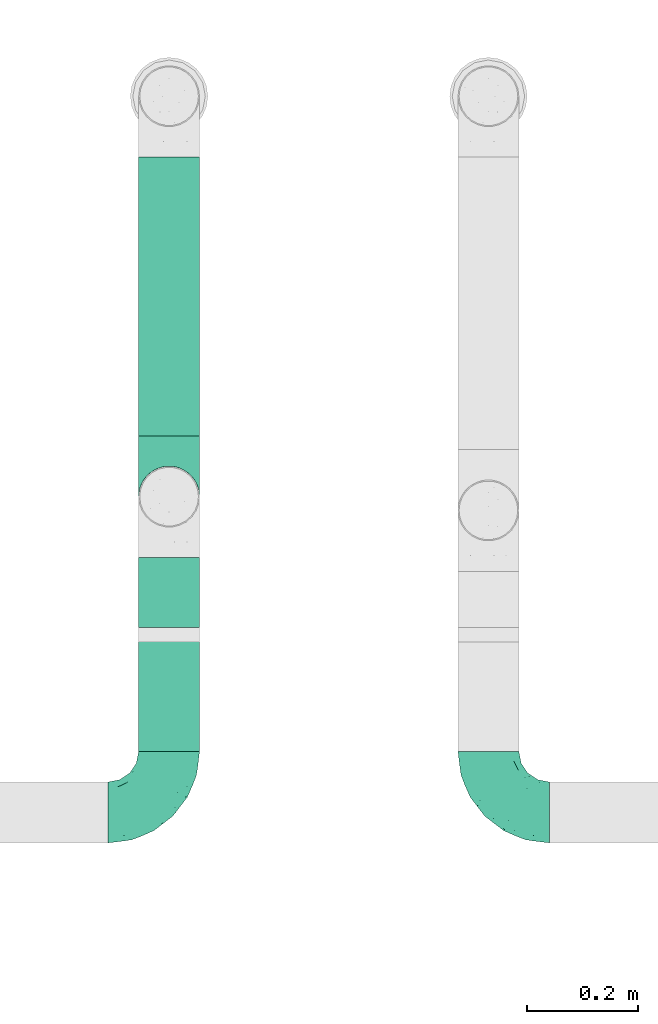
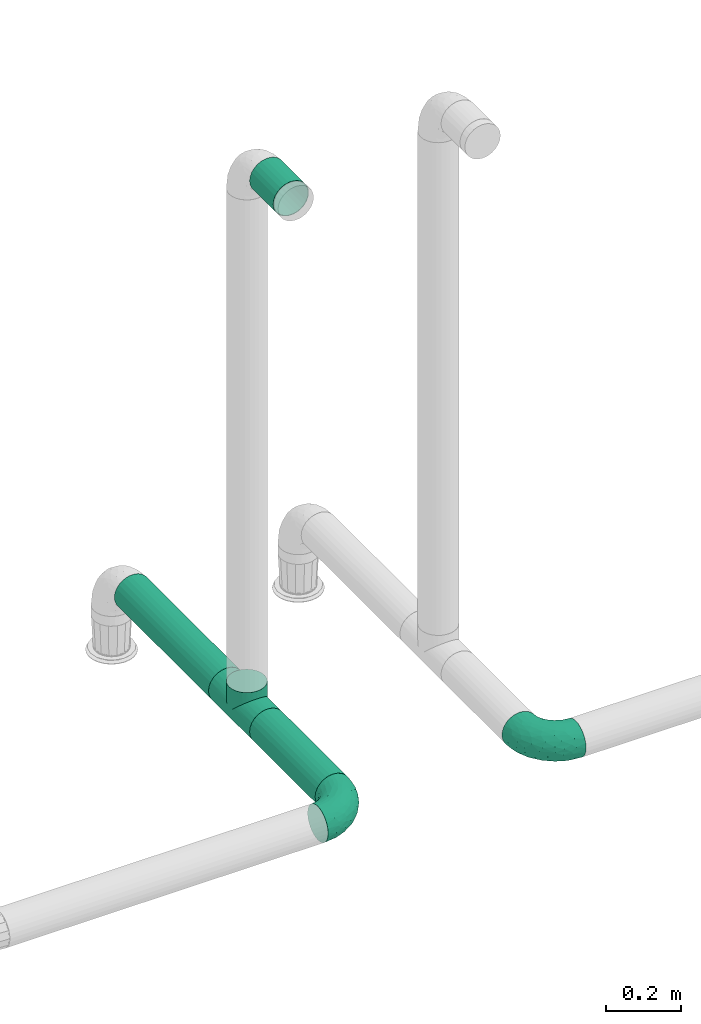
# One storey, part 58 of 103: 3 flow fittings, 3 flow segments.
"""IFC2X3 building model written with IfcOpenShell, lengths in millimetres."""

from ifc_helpers import new_model, entity, si_unit, converted_unit, derived_unit, direction, frame, origin_with_axes, origin_2d_with_axis, place, context, subcontext, project, spatial, hollow_circle, extrude, open_shell, surface_model, source, transform, mapped, material, layer, layer_set, layer_usage, type_object, element, save


model = new_model("IFC2X3")

# Units and contexts
model_context = context("Model", 3, precision=1e-05, world=origin_with_axes(), true_north=direction((0.0, 1.0)))
body_context = subcontext(model_context, "Body", "Model", "MODEL_VIEW")
ifc_project = project(units=[si_unit("AREAUNIT", "SQUARE_METRE"), si_unit("VOLUMEUNIT", "CUBIC_METRE", prefix="DECI"), si_unit("TIMEUNIT", "SECOND"), si_unit("THERMODYNAMICTEMPERATUREUNIT", "DEGREE_CELSIUS"), si_unit("PRESSUREUNIT", "PASCAL"), si_unit("MASSUNIT", "GRAM", prefix="KILO"), si_unit("LENGTHUNIT", "METRE", prefix="MILLI"), si_unit("POWERUNIT", "WATT"), si_unit("ELECTRICCURRENTUNIT", "AMPERE"), si_unit("ELECTRICVOLTAGEUNIT", "VOLT"), derived_unit("VOLUMETRICFLOWRATEUNIT", [(si_unit("VOLUMEUNIT", "CUBIC_METRE", prefix="DECI"), 1), (si_unit("TIMEUNIT", "SECOND"), -1)]), derived_unit("LINEARVELOCITYUNIT", [(si_unit("LENGTHUNIT", "METRE"), 1), (si_unit("TIMEUNIT", "SECOND"), -1)]), derived_unit("MASSDENSITYUNIT", [(si_unit("MASSUNIT", "GRAM", prefix="KILO"), 1), (si_unit("VOLUMEUNIT", "CUBIC_METRE"), -1)]), converted_unit("PLANEANGLEUNIT", "DEGREE", entity("IfcRatioMeasure", 0.01745), si_unit("PLANEANGLEUNIT", "RADIAN"), dimensions=[0, 0, 0, 0, 0, 0, 0])], contexts=[model_context])

# Site, building, storey
site_placement = place(None, origin_with_axes())
site = spatial("IfcSite", under=ifc_project, at=site_placement, CompositionType="ELEMENT")
building_placement = place(site_placement, origin_with_axes())
building = spatial("IfcBuilding", under=site, at=building_placement, Name="mc-building", CompositionType="ELEMENT")
storey_placement = place(building_placement, frame((0.0, 0.0, 5900.0), z_axis=(0.0, 0.0, 1.0), x_axis=(1.0, 0.0, 0.0)))
storey = spatial("IfcBuildingStorey", under=building, at=storey_placement, Name="3. Korrus", CompositionType="ELEMENT", Elevation=5900.0)

# Flow fittings
duct_fitting_type_1 = type_object("IfcDuctFittingType", PredefinedType="JUNCTION")
shared_shape_1 = source(origin_with_axes(), body_context, "Body", "SurfaceModel", [
    surface_model("IfcShellBasedSurfaceModel", [(0.0, -80.0, -55.0), (14.23505, -80.0, -53.12592), (-14.23505, -80.0, -53.12592), (-53.12592, -80.0, 14.23505), (-27.5, -80.0, -47.63139), (-47.63139, -80.0, -27.5), (-38.89087, -80.0, -38.89087), (55.0, -80.0, 0.0), (53.12592, -80.0, 14.23505), (38.89087, -80.0, -38.89087), (27.5, -80.0, -47.63139), (53.12592, -80.0, -14.23505), (47.63139, -80.0, -27.5), (-53.12592, -80.0, -14.23505), (-47.63139, -80.0, 27.5), (-38.89087, -80.0, 38.89087), (14.23505, -80.0, 53.12592), (-27.5, -80.0, 47.63139), (-14.23505, -80.0, 53.12592), (47.63139, -80.0, 27.5), (38.89087, -80.0, 38.89087), (27.5, -80.0, 47.63139), (0.0, -80.0, 55.0), (-55.0, -80.0, 0.0), (0.0, 0.0, 55.0), (-7.4066, -7.4066, 54.49901), (-14.74521, -14.74521, 52.98659), (-21.93978, -21.93978, 50.43457), (-28.89905, -28.89905, 46.79578), (-35.50357, -35.50357, 42.00591), (-41.58668, -41.58668, 35.99373), (-46.92319, -46.92319, 28.69171), (-51.19777, -51.19777, 20.0945), (-50.37866, -80.0, 20.86752), (-54.01174, -54.01174, 10.37938), (-55.0, -55.0, 0.0), (-54.06296, -80.0, 7.11752), (-54.01174, -54.01174, -10.37938), (-51.19777, -51.19777, -20.0945), (-54.06296, -80.0, -7.11752), (-46.92319, -46.92319, -28.69171), (-41.58668, -41.58668, -35.99373), (-50.37866, -80.0, -20.86752), (-35.50357, -35.50357, -42.00591), (-21.93978, -21.93978, -50.43457), (-14.74521, -14.74521, -52.98659), (-7.4066, -7.4066, -54.49901), (0.0, 0.0, -55.0), (-28.89905, -28.89905, -46.79578), (7.4066, -7.4066, -54.49901), (14.74521, -14.74521, -52.98659), (21.93978, -21.93978, -50.43457), (28.89905, -28.89905, -46.79578), (35.50357, -35.50357, -42.00591), (41.58668, -41.58668, -35.99373), (46.92319, -46.92319, -28.69171), (51.19777, -51.19777, -20.0945), (50.37866, -80.0, -20.86752), (54.01174, -54.01174, -10.37938), (55.0, -55.0, 0.0), (54.06296, -80.0, -7.11752), (54.01174, -54.01174, 10.37938), (51.19777, -51.19777, 20.0945), (54.06296, -80.0, 7.11752), (46.92319, -46.92319, 28.69171), (41.58668, -41.58668, 35.99373), (50.37866, -80.0, 20.86752), (35.50357, -35.50357, 42.00591), (21.93978, -21.93978, 50.43457), (14.74521, -14.74521, 52.98659), (7.4066, -7.4066, 54.49901), (28.89905, -28.89905, 46.79578), (-110.0, 0.0, -55.0), (-110.0, -14.23505, -53.12592), (-110.0, 14.23505, -53.12592), (-110.0, 53.12592, 14.23505), (-110.0, 27.5, -47.63139), (-110.0, 47.63139, -27.5), (-110.0, 38.89087, -38.89087), (-110.0, -55.0, 0.0), (-110.0, -53.12592, 14.23505), (-110.0, -38.89087, -38.89087), (-110.0, -27.5, -47.63139), (-110.0, -53.12592, -14.23505), (-110.0, -47.63139, -27.5), (-110.0, 53.12592, -14.23505), (-110.0, 47.63139, 27.5), (-110.0, 38.89087, 38.89087), (-110.0, -14.23505, 53.12592), (-110.0, 27.5, 47.63139), (-110.0, 14.23505, 53.12592), (-110.0, -47.63139, 27.5), (-110.0, -38.89087, 38.89087), (-110.0, -27.5, 47.63139), (-110.0, 0.0, 55.0), (-110.0, 55.0, 0.0), (110.0, 55.0, 0.0), (110.0, 0.0, -55.0), (110.0, 14.23505, -53.12592), (110.0, 27.5, -47.63139), (110.0, 38.89087, -38.89087), (110.0, 47.63139, -27.5), (110.0, -38.89087, -38.89087), (110.0, -53.12592, 14.23505), (110.0, -27.5, -47.63139), (110.0, -14.23505, -53.12592), (110.0, -47.63139, -27.5), (110.0, -53.12592, -14.23505), (110.0, -55.0, 0.0), (110.0, 53.12592, -14.23505), (110.0, 53.12592, 14.23505), (110.0, 47.63139, 27.5), (110.0, 38.89087, 38.89087), (110.0, 0.0, 55.0), (110.0, 27.5, 47.63139), (110.0, 14.23505, 53.12592), (110.0, -47.63139, 27.5), (110.0, -38.89087, 38.89087), (110.0, -27.5, 47.63139), (110.0, -14.23505, 53.12592)], [open_shell([[[0, 1, 2]], [[2, 3, 4]], [[5, 6, 3]], [[6, 4, 3]], [[2, 7, 8]], [[9, 7, 10]], [[1, 10, 7]], [[11, 7, 12]], [[9, 12, 7]], [[7, 2, 1]], [[5, 3, 13]], [[2, 14, 3]], [[2, 15, 14]], [[2, 16, 17]], [[17, 15, 2]], [[16, 18, 17]], [[2, 8, 19]], [[2, 19, 20]], [[2, 20, 21]], [[16, 2, 21]], [[16, 22, 18]], [[23, 13, 3]], [[24, 25, 22]], [[26, 27, 18]], [[25, 26, 18]], [[22, 25, 18]], [[17, 28, 29]], [[17, 18, 27]], [[17, 29, 15]], [[28, 17, 27]], [[30, 31, 14]], [[32, 3, 33]], [[32, 34, 3]], [[35, 36, 34]], [[31, 32, 14]], [[15, 30, 14]], [[34, 36, 3]], [[33, 14, 32]], [[36, 35, 23]], [[30, 15, 29]], [[37, 38, 13]], [[37, 13, 39]], [[40, 41, 5]], [[38, 5, 42]], [[38, 40, 5]], [[37, 39, 35]], [[35, 39, 23]], [[13, 38, 42]], [[41, 6, 5]], [[41, 43, 6]], [[44, 45, 2]], [[46, 47, 0]], [[45, 46, 2]], [[43, 48, 4]], [[44, 4, 48]], [[44, 2, 4]], [[46, 0, 2]], [[43, 4, 6]], [[47, 49, 0]], [[50, 51, 1]], [[49, 50, 1]], [[0, 49, 1]], [[10, 52, 53]], [[10, 1, 51]], [[10, 53, 9]], [[52, 10, 51]], [[54, 55, 12]], [[56, 11, 57]], [[56, 58, 11]], [[59, 60, 58]], [[55, 56, 12]], [[9, 54, 12]], [[58, 60, 11]], [[57, 12, 56]], [[60, 59, 7]], [[54, 9, 53]], [[61, 62, 8]], [[61, 8, 63]], [[64, 65, 19]], [[62, 19, 66]], [[62, 64, 19]], [[61, 63, 59]], [[7, 59, 63]], [[62, 66, 8]], [[65, 20, 19]], [[65, 67, 20]], [[68, 69, 16]], [[70, 24, 22]], [[69, 70, 16]], [[67, 71, 21]], [[68, 21, 71]], [[68, 16, 21]], [[70, 22, 16]], [[67, 21, 20]], [[72, 73, 74]], [[74, 75, 76]], [[77, 78, 75]], [[76, 75, 78]], [[74, 79, 80]], [[81, 79, 82]], [[73, 82, 79]], [[83, 79, 84]], [[81, 84, 79]], [[79, 74, 73]], [[77, 75, 85]], [[74, 86, 75]], [[74, 87, 86]], [[74, 88, 89]], [[89, 87, 74]], [[88, 90, 89]], [[74, 91, 92]], [[91, 74, 80]], [[92, 93, 74]], [[74, 93, 88]], [[88, 94, 90]], [[95, 85, 75]], [[96, 97, 98]], [[99, 96, 98]], [[96, 100, 101]], [[100, 96, 99]], [[102, 97, 103]], [[97, 102, 104]], [[104, 105, 97]], [[102, 103, 106]], [[106, 103, 107]], [[108, 107, 103]], [[109, 96, 101]], [[110, 111, 97]], [[97, 111, 112]], [[113, 97, 114]], [[97, 112, 114]], [[113, 114, 115]], [[116, 103, 97]], [[117, 116, 97]], [[118, 117, 97]], [[119, 118, 97]], [[119, 97, 113]], [[96, 110, 97]], [[24, 113, 115]], [[89, 115, 114]], [[94, 24, 90]], [[90, 24, 115]], [[115, 89, 90]], [[114, 87, 89]], [[86, 112, 111]], [[75, 111, 110]], [[95, 110, 96]], [[87, 112, 86]], [[86, 111, 75]], [[110, 95, 75]], [[112, 87, 114]], [[85, 96, 109]], [[77, 109, 101]], [[95, 96, 85]], [[85, 109, 77]], [[101, 78, 77]], [[101, 100, 78]], [[76, 100, 99]], [[74, 99, 98]], [[47, 98, 97]], [[76, 99, 74]], [[47, 72, 74]], [[98, 47, 74]], [[100, 76, 78]], [[47, 46, 72]], [[45, 44, 73]], [[46, 45, 73]], [[72, 46, 73]], [[82, 48, 43]], [[82, 73, 44]], [[82, 43, 81]], [[48, 82, 44]], [[41, 40, 84]], [[38, 37, 83]], [[40, 38, 84]], [[81, 41, 84]], [[37, 79, 83]], [[83, 84, 38]], [[79, 37, 35]], [[41, 81, 43]], [[49, 97, 105]], [[105, 104, 51]], [[53, 104, 102]], [[53, 52, 104]], [[49, 47, 97]], [[51, 50, 105]], [[52, 51, 104]], [[49, 105, 50]], [[54, 102, 106]], [[56, 106, 107]], [[58, 107, 108]], [[55, 54, 106]], [[58, 56, 107]], [[59, 58, 108]], [[55, 106, 56]], [[102, 54, 53]], [[34, 32, 80]], [[31, 30, 91]], [[32, 31, 91]], [[35, 34, 79]], [[80, 79, 34]], [[32, 91, 80]], [[30, 92, 91]], [[30, 29, 92]], [[27, 26, 88]], [[25, 24, 94]], [[26, 25, 88]], [[29, 28, 93]], [[27, 93, 28]], [[27, 88, 93]], [[25, 94, 88]], [[29, 93, 92]], [[61, 108, 103]], [[62, 103, 116]], [[65, 116, 117]], [[61, 59, 108]], [[64, 62, 116]], [[65, 64, 116]], [[61, 103, 62]], [[117, 67, 65]], [[71, 67, 118]], [[118, 67, 117]], [[68, 118, 119]], [[70, 119, 113]], [[68, 71, 118]], [[70, 69, 119]], [[24, 70, 113]], [[68, 119, 69]]])]),
])
flow_fitting_placement = place(storey_placement, frame((26088.96136, 4007.31628, 2345.0), z_axis=(-1.0, 0.0, 0.0), x_axis=(0.0, 1.0, 0.0)))
element("IfcFlowFitting", 1, at=flow_fitting_placement, inside=storey, type_object=duct_fitting_type_1, context=body_context, shape_type="MappedRepresentation", body=[
    mapped(shared_shape_1, transform((0.0, 0.0, 0.0), scale=1.0)),
])
duct_fitting_type_2 = type_object("IfcDuctFittingType", Name="BU", PredefinedType="BEND")
shared_shape_2 = source(origin_with_axes(), body_context, "Body", "SurfaceModel", [
    surface_model("IfcShellBasedSurfaceModel", [(-110.0, 0.0, -55.0), (-110.0, -14.23505, -53.12592), (-110.0, 14.23505, -53.12592), (-110.0, 53.12592, 14.23505), (-110.0, 27.5, -47.63139), (-110.0, 38.89087, -38.89087), (-110.0, -55.0, 0.0), (-110.0, -53.12592, 14.23505), (-110.0, -38.89087, -38.89087), (-110.0, -27.5, -47.63139), (-110.0, -53.12592, -14.23505), (-110.0, -47.63139, -27.5), (-110.0, -14.23505, 53.12592), (-110.0, 14.23505, 53.12592), (-110.0, 27.5, 47.63139), (-110.0, -47.63139, 27.5), (-110.0, -38.89087, 38.89087), (-110.0, -27.5, 47.63139), (-110.0, 0.0, 55.0), (-110.0, 55.0, 0.0), (-110.0, 53.12592, -14.23505), (-110.0, 47.63139, -27.5), (-110.0, 47.63139, 27.5), (-110.0, 38.89087, 38.89087), (-14.23505, 110.0, -53.12592), (-55.0, 110.0, 0.0), (0.0, 110.0, -55.0), (-27.5, 110.0, -47.63139), (-38.89087, 110.0, -38.89087), (-47.63139, 110.0, -27.5), (38.89087, 110.0, -38.89087), (53.12592, 110.0, 14.23505), (27.5, 110.0, -47.63139), (14.23505, 110.0, -53.12592), (47.63139, 110.0, -27.5), (53.12592, 110.0, -14.23505), (55.0, 110.0, 0.0), (-53.12592, 110.0, -14.23505), (-53.12592, 110.0, 14.23505), (-47.63139, 110.0, 27.5), (-38.89087, 110.0, 38.89087), (-27.5, 110.0, 47.63139), (0.0, 110.0, 55.0), (-14.23505, 110.0, 53.12592), (38.89087, 110.0, 38.89087), (47.63139, 110.0, 27.5), (27.5, 110.0, 47.63139), (14.23505, 110.0, 53.12592), (-64.21732, 48.68956, 43.63444), (-76.6405, 38.18013, 45.55988), (-60.44912, 32.56953, 51.94617), (-76.00813, 5.38378, 55.0), (-90.15553, 11.94394, 54.09138), (-78.5998, 26.77405, 50.81338), (-70.18771, 18.55163, 54.03432), (-75.55424, 54.2118, 32.41257), (-93.27622, 45.77614, 33.48188), (-96.12334, 22.13664, 50.81337), (-21.00813, 45.34362, 55.0), (-18.36258, 70.48427, 54.04484), (-32.04182, 59.64019, 52.24446), (-63.88653, 74.77858, 17.99134), (-74.66383, 63.08407, 19.92123), (-63.60674, 66.07878, 29.97482), (-99.597, 52.72185, 18.52927), (-93.11138, 56.59448, 10.50359), (-98.21577, 57.34403, 0.0), (-53.42855, 92.60092, 21.04759), (-88.54852, 54.8376, 21.04759), (-11.86161, 90.23965, 54.10313), (-5.38378, 76.00813, 55.0), (-57.34403, 98.21577, 0.0), (-56.64619, 93.12774, 10.22088), (-45.34362, 21.00813, 55.0), (-44.60838, 44.60838, 52.13415), (-92.68484, 35.46673, 43.63443), (-22.25266, 95.40765, 50.81337), (-35.97783, 90.61597, 43.63443), (-43.70931, 69.58671, 44.47149), (-27.23711, 77.39884, 50.81337), (-57.2828, 79.3123, 24.9774), (-58.67786, 84.31125, 16.04456), (-82.93277, 60.36161, 12.91784), (-49.88337, 54.51816, 47.224), (-74.57753, 66.83759, 9.55742), (-45.35812, 94.97281, 33.48188), (-59.18663, 88.95241, 0.0), (-51.517, 78.6292, 33.48188), (-65.14788, 80.03077, 0.0), (-56.45322, 62.06476, 39.63545), (-88.95241, 59.18663, 0.0), (-71.10913, 71.10913, 0.0), (-80.03077, 65.14788, 0.0), (-94.9309, 45.36788, -33.48188), (-93.11358, 56.60141, -10.46614), (-99.64997, 52.79499, -18.30015), (-90.20425, 36.08686, -43.63443), (-79.99933, 46.56772, -37.92748), (-76.00813, 5.38378, -55.0), (-72.75364, 19.68651, -53.60527), (-45.34362, 21.00813, -55.0), (-21.91957, 65.12078, -53.85897), (-5.38378, 76.00813, -55.0), (-21.00813, 45.34362, -55.0), (-35.41876, 92.89265, -43.63443), (-91.10309, 11.02766, -54.21832), (-45.77614, 93.27622, -33.48188), (-90.50474, 23.21022, -50.81337), (-70.92854, 33.31794, -49.51754), (-78.52933, 63.35627, -11.73997), (-24.91508, 84.05606, -50.81337), (-88.78941, 54.74452, -21.04759), (-69.59921, 57.34866, -33.48187), (-73.36422, 62.46673, -22.94182), (-63.49062, 67.59111, -28.46929), (-56.59448, 93.11138, -10.50359), (-54.8376, 88.54852, -21.04759), (-54.10679, 75.85581, -32.31867), (-57.75956, 31.09612, -52.80882), (-52.72185, 99.597, -18.52927), (-12.62913, 89.46304, -53.99097), (-34.46825, 66.46123, -50.04329), (-43.9837, 43.9837, -52.42279), (-65.78527, 72.58348, -17.68796), (-70.34468, 43.65295, -44.21951), (-57.47001, 51.99467, -44.91465), (-60.72547, 82.29174, -12.88567), (-42.34915, 74.24548, -43.63444), (-57.25194, 63.5016, -38.08211), (-80.95344, 53.56991, -29.32027), (-52.32891, 4.55257, -54.0482), (32.52942, 47.13398, -30.48571), (14.88266, 20.92917, -33.7947), (14.95561, 36.05775, -42.26543), (30.24048, 70.09027, -41.7461), (19.3559, 65.35825, -48.00507), (-70.35075, -46.44478, -19.5952), (-47.13398, -32.52942, -30.48571), (-28.49299, -30.5778, -16.4009), (-4.55257, 52.32891, -54.0482), (-22.4954, 22.4954, -53.25347), (-75.47368, -11.22546, -52.60718), (-81.32209, -51.5606, -9.98467), (-80.81763, -41.84862, -32.14655), (-70.09027, -30.24048, -41.7461), (-36.05774, -14.95561, -42.26543), (-9.15831, -10.852, -27.8997), (-65.35825, -19.3559, -48.00507), (11.22546, 75.47368, -52.60718), (3.94376, 43.9333, -50.53315), (-13.39742, 13.39743, -48.13058), (-43.9333, -3.94376, -50.53315), (49.37776, 67.29486, 0.0), (41.8609, 47.82256, -9.92641), (50.20582, 74.51695, -9.9731), (18.93131, 11.7156, -17.56239), (-27.5, -32.89419, 0.0), (-1.23348, -12.25375, -12.18106), (41.84862, 80.81763, -32.14655), (35.70604, 41.31408, -20.38235), (46.44478, 70.35075, -19.5952), (32.89419, 27.5, 0.0), (6.67262, -6.67262, 0.0), (-67.29486, -49.37776, 0.0), (-50.36265, -42.95545, -9.51562), (-5.47251, 5.47251, -39.92906), (-70.35075, -46.44478, 19.5952), (-74.51695, -50.20582, 9.9731), (-41.31407, -35.70604, 20.38235), (-47.13398, -32.52942, 30.48571), (-80.81763, -41.84862, 32.14655), (-4.55257, 52.32891, 54.0482), (11.22546, 75.47368, 52.60718), (-43.9333, -3.94376, 50.53315), (-65.35825, -19.3559, 48.00507), (-36.05774, -14.95561, 42.26543), (-70.09027, -30.24048, 41.7461), (-11.7156, -18.93131, 17.56239), (30.5778, 28.49299, 16.4009), (12.25375, 1.23348, 12.18106), (51.5606, 81.32209, 9.98467), (42.95545, 50.36265, 9.51562), (-75.47368, -11.22546, 52.60718), (-52.32891, 4.55257, 54.0482), (3.94376, 43.9333, 50.53315), (-22.4954, 22.4954, 53.25347), (-13.39742, 13.39743, 48.13058), (10.852, 9.15831, 27.8997), (-20.92916, -14.88266, 33.79469), (-47.82256, -41.8609, 9.92641), (32.52942, 47.13398, 30.48571), (46.44478, 70.35075, 19.5952), (41.84862, 80.81763, 32.14655), (30.24048, 70.09027, 41.7461), (19.3559, 65.35825, 48.00507), (14.95561, 36.05775, 42.26543), (-5.47251, 5.47251, 39.92906)], [open_shell([[[0, 1, 2]], [[2, 3, 4]], [[4, 3, 5]], [[2, 6, 7]], [[8, 6, 9]], [[1, 9, 6]], [[10, 6, 11]], [[8, 11, 6]], [[6, 2, 1]], [[12, 13, 14]], [[15, 2, 7]], [[16, 17, 2]], [[2, 17, 12]], [[12, 18, 13]], [[19, 20, 3]], [[5, 3, 21]], [[20, 21, 3]], [[22, 3, 2]], [[23, 22, 2]], [[12, 14, 2]], [[2, 14, 23]], [[15, 16, 2]], [[24, 25, 26]], [[27, 25, 24]], [[25, 28, 29]], [[28, 25, 27]], [[30, 26, 31]], [[26, 30, 32]], [[32, 33, 26]], [[34, 31, 35]], [[31, 34, 30]], [[35, 31, 36]], [[29, 37, 25]], [[38, 39, 26]], [[39, 40, 26]], [[41, 42, 40]], [[42, 26, 40]], [[42, 41, 43]], [[26, 44, 45]], [[31, 26, 45]], [[26, 46, 44]], [[47, 46, 26]], [[42, 47, 26]], [[25, 38, 26]], [[48, 49, 50]], [[18, 51, 52]], [[53, 54, 50]], [[55, 56, 49]], [[56, 22, 23]], [[13, 57, 14]], [[58, 59, 60]], [[61, 62, 63]], [[3, 64, 65]], [[53, 52, 54]], [[3, 65, 66]], [[67, 39, 38]], [[56, 68, 64]], [[65, 64, 68]], [[69, 59, 70]], [[38, 71, 72]], [[73, 58, 74]], [[75, 49, 56]], [[76, 69, 43]], [[53, 57, 52]], [[77, 78, 79]], [[41, 76, 43]], [[43, 69, 42]], [[55, 68, 56]], [[23, 14, 75]], [[76, 77, 79]], [[80, 67, 81]], [[62, 82, 68]], [[60, 78, 83]], [[62, 84, 82]], [[85, 77, 40]], [[81, 67, 72]], [[86, 72, 71]], [[87, 85, 67]], [[61, 81, 88]], [[77, 41, 40]], [[78, 77, 87]], [[23, 75, 56]], [[83, 89, 48]], [[85, 40, 39]], [[62, 68, 55]], [[89, 87, 63]], [[83, 48, 50]], [[57, 75, 14]], [[49, 75, 53]], [[67, 85, 39]], [[87, 77, 85]], [[63, 62, 55]], [[89, 55, 48]], [[80, 63, 87]], [[66, 65, 90]], [[66, 19, 3]], [[84, 91, 92]], [[92, 90, 82]], [[65, 82, 90]], [[61, 84, 62]], [[92, 82, 84]], [[68, 82, 65]], [[3, 22, 64]], [[56, 64, 22]], [[38, 25, 71]], [[81, 72, 86]], [[38, 72, 67]], [[91, 61, 88]], [[80, 81, 61]], [[63, 80, 61]], [[67, 80, 87]], [[77, 76, 41]], [[79, 59, 69]], [[79, 69, 76]], [[42, 69, 70]], [[60, 59, 79]], [[58, 70, 59]], [[78, 60, 79]], [[58, 60, 74]], [[52, 57, 13]], [[75, 57, 53]], [[18, 52, 13]], [[52, 51, 54]], [[51, 73, 54]], [[50, 73, 74]], [[73, 50, 54]], [[50, 74, 83]], [[60, 83, 74]], [[89, 83, 78]], [[87, 89, 78]], [[55, 89, 63]], [[50, 49, 53]], [[55, 49, 48]], [[81, 86, 88]], [[91, 84, 61]], [[5, 21, 93]], [[90, 94, 66]], [[20, 94, 95]], [[96, 93, 97]], [[98, 99, 100]], [[96, 4, 5]], [[101, 102, 103]], [[28, 27, 104]], [[2, 105, 0]], [[104, 106, 28]], [[99, 105, 107]], [[108, 107, 96]], [[90, 109, 94]], [[107, 2, 4]], [[20, 66, 94]], [[27, 24, 110]], [[109, 111, 94]], [[112, 113, 114]], [[37, 115, 71]], [[116, 106, 117]], [[99, 118, 100]], [[116, 115, 119]], [[37, 119, 115]], [[24, 120, 110]], [[121, 110, 101]], [[119, 106, 116]], [[101, 110, 120]], [[122, 103, 100]], [[117, 123, 116]], [[124, 125, 108]], [[115, 116, 126]], [[106, 29, 28]], [[26, 102, 120]], [[127, 104, 110]], [[97, 124, 96]], [[125, 122, 118]], [[128, 127, 125]], [[96, 5, 93]], [[115, 126, 86]], [[117, 106, 127]], [[111, 113, 129]], [[95, 93, 21]], [[97, 129, 112]], [[110, 104, 27]], [[106, 104, 127]], [[96, 107, 4]], [[99, 107, 108]], [[99, 108, 118]], [[105, 99, 98]], [[112, 114, 128]], [[121, 125, 127]], [[20, 19, 66]], [[109, 90, 92]], [[94, 111, 95]], [[91, 123, 109]], [[129, 113, 112]], [[93, 95, 111]], [[21, 20, 95]], [[71, 115, 86]], [[71, 25, 37]], [[123, 91, 88]], [[126, 116, 123]], [[123, 88, 126]], [[86, 126, 88]], [[37, 29, 119]], [[106, 119, 29]], [[129, 93, 111]], [[124, 112, 125]], [[0, 105, 98]], [[107, 105, 2]], [[125, 118, 108]], [[100, 118, 122]], [[93, 129, 97]], [[113, 111, 109]], [[109, 123, 113]], [[114, 123, 117]], [[123, 114, 113]], [[128, 114, 117]], [[127, 128, 117]], [[112, 128, 125]], [[103, 122, 101]], [[110, 121, 127]], [[101, 122, 121]], [[125, 121, 122]], [[26, 120, 24]], [[101, 120, 102]], [[96, 124, 108]], [[92, 91, 109]], [[112, 124, 97]], [[100, 130, 98]], [[131, 132, 133]], [[32, 134, 135]], [[136, 137, 138]], [[139, 140, 103]], [[98, 141, 0]], [[142, 10, 136]], [[143, 144, 137]], [[6, 10, 142]], [[137, 145, 146]], [[144, 147, 145]], [[143, 136, 11]], [[11, 136, 10]], [[8, 143, 11]], [[148, 149, 139]], [[8, 9, 144]], [[9, 1, 147]], [[130, 141, 98]], [[103, 140, 100]], [[148, 135, 149]], [[150, 151, 140]], [[152, 153, 154]], [[130, 140, 151]], [[148, 26, 33]], [[147, 1, 141]], [[155, 146, 132]], [[156, 138, 157]], [[134, 30, 158]], [[150, 140, 149]], [[158, 30, 34]], [[30, 134, 32]], [[153, 159, 160]], [[131, 160, 159]], [[144, 145, 137]], [[36, 152, 154]], [[146, 138, 137]], [[155, 161, 162]], [[158, 160, 131]], [[133, 149, 135]], [[156, 163, 164]], [[163, 142, 164]], [[139, 103, 102]], [[153, 152, 161]], [[34, 35, 160]], [[162, 157, 155]], [[132, 165, 133]], [[157, 146, 155]], [[140, 130, 100]], [[141, 130, 151]], [[141, 151, 147]], [[141, 1, 0]], [[102, 26, 148]], [[140, 139, 149]], [[102, 148, 139]], [[135, 33, 32]], [[151, 150, 145]], [[9, 147, 144]], [[151, 145, 147]], [[145, 165, 146]], [[135, 148, 33]], [[133, 135, 134]], [[131, 133, 134]], [[133, 165, 150]], [[133, 150, 149]], [[145, 150, 165]], [[132, 131, 159]], [[146, 165, 132]], [[160, 158, 34]], [[134, 158, 131]], [[144, 143, 8]], [[136, 143, 137]], [[155, 153, 161]], [[154, 153, 160]], [[153, 155, 159]], [[132, 159, 155]], [[160, 35, 154]], [[36, 154, 35]], [[164, 136, 138]], [[6, 142, 163]], [[136, 164, 142]], [[156, 164, 138]], [[156, 157, 162]], [[146, 157, 138]], [[15, 7, 166]], [[6, 163, 167]], [[168, 169, 166]], [[166, 169, 170]], [[171, 172, 70]], [[173, 174, 175]], [[17, 176, 174]], [[177, 156, 162]], [[176, 16, 170]], [[170, 16, 15]], [[161, 178, 179]], [[152, 180, 181]], [[182, 173, 183]], [[18, 12, 182]], [[184, 185, 186]], [[183, 185, 73]], [[183, 73, 51]], [[177, 187, 188]], [[189, 168, 166]], [[187, 178, 190]], [[16, 176, 17]], [[161, 152, 181]], [[45, 191, 31]], [[45, 44, 192]], [[192, 191, 45]], [[180, 36, 31]], [[193, 194, 195]], [[46, 47, 194]], [[193, 195, 190]], [[193, 44, 46]], [[172, 42, 70]], [[185, 58, 73]], [[189, 163, 156]], [[163, 189, 167]], [[70, 58, 171]], [[184, 171, 185]], [[169, 188, 175]], [[180, 31, 191]], [[192, 193, 190]], [[191, 190, 178]], [[182, 174, 173]], [[194, 47, 172]], [[190, 195, 187]], [[186, 185, 173]], [[162, 179, 177]], [[188, 196, 175]], [[179, 187, 177]], [[185, 171, 58]], [[172, 171, 184]], [[172, 184, 194]], [[172, 47, 42]], [[51, 18, 182]], [[185, 183, 173]], [[51, 182, 183]], [[174, 12, 17]], [[184, 186, 195]], [[46, 194, 193]], [[184, 195, 194]], [[195, 196, 187]], [[174, 182, 12]], [[175, 174, 176]], [[169, 175, 176]], [[175, 196, 186]], [[175, 186, 173]], [[195, 186, 196]], [[188, 169, 168]], [[187, 196, 188]], [[166, 170, 15]], [[176, 170, 169]], [[193, 192, 44]], [[191, 192, 190]], [[177, 189, 156]], [[167, 189, 166]], [[189, 177, 168]], [[188, 168, 177]], [[166, 7, 167]], [[6, 167, 7]], [[181, 191, 178]], [[36, 180, 152]], [[191, 181, 180]], [[161, 181, 178]], [[161, 179, 162]], [[187, 179, 178]]])]),
])
for number, where, z_axis, x_axis, name in (
    (2, (26088.96136, 3436.80698, 2345.0), (0.0, 0.0, 1.0), (1.0, 0.0, 0.0), "BU"),
    (3, (26665.96154, 3436.80698, 2345.0), (0.0, 0.0, 1.0), (0.0, -1.0, 0.0), "BU"),
):
    element("IfcFlowFitting", number, at=place(storey_placement, frame(where, z_axis=z_axis, x_axis=x_axis)), inside=storey, type_object=duct_fitting_type_2, Name=name, context=body_context, shape_type="MappedRepresentation", body=[
        mapped(shared_shape_2, transform((0.0, 0.0, 0.0), scale=1.0)),
    ])

# Flow segments
ifc_material = material(Name="FZ1")
ifc_layer = layer(ifc_material, 0.0)
ifc_layer_set = layer_set([ifc_layer], Name="FZ1")
ifc_layer_usage = layer_usage(ifc_layer_set, "AXIS1", "POSITIVE", 0.0)
duct_segment_type = type_object("IfcDuctSegmentType", Name="Safe", PredefinedType="RIGIDSEGMENT")
shared_shape_3 = source(origin_with_axes(), body_context, "Body", "SweptSolid", [
    extrude(hollow_circle(Radius=55.0, WallThickness=2.0, at=origin_2d_with_axis()), frame((0.0, 0.0, 0.0), z_axis=(1.0, 0.0, 0.0), x_axis=(0.0, 1.0, 0.0)), (0.0, 0.0, 1.0), 503.5),
])
flow_segment_1_placement = place(storey_placement, frame((26088.96136, 4117.31628, 2345.0), z_axis=(0.0, 0.0, 1.0), x_axis=(0.0, 1.0, 0.0)))
element("IfcFlowSegment", 4, at=flow_segment_1_placement, inside=storey, type_object=duct_segment_type, material=ifc_layer_usage, Name="Safe", context=body_context, shape_type="MappedRepresentation", body=[
    mapped(shared_shape_3, transform((0.0, 0.0, 0.0), scale=1.0)),
])
shared_shape_4 = source(origin_with_axes(), body_context, "Body", "SweptSolid", [
    extrude(hollow_circle(Radius=55.0, WallThickness=2.0, at=origin_2d_with_axis()), frame((0.0, 0.0, 0.0), z_axis=(1.0, 0.0, 0.0), x_axis=(0.0, 1.0, 0.0)), (0.0, 0.0, 1.0), 350.5),
])
flow_segment_2_placement = place(storey_placement, frame((26088.96136, 3546.80698, 2345.0), z_axis=(0.0, 0.0, 1.0), x_axis=(0.0, 1.0, 0.0)))
element("IfcFlowSegment", 5, at=flow_segment_2_placement, inside=storey, type_object=duct_segment_type, material=ifc_layer_usage, Name="Safe", context=body_context, shape_type="MappedRepresentation", body=[
    mapped(shared_shape_4, transform((0.0, 0.0, 0.0), scale=1.0)),
])
shared_shape_5 = source(origin_with_axes(), body_context, "Body", "SweptSolid", [
    extrude(hollow_circle(Radius=55.0, WallThickness=2.0, at=origin_2d_with_axis()), frame((0.0, 0.0, 0.0), z_axis=(1.0, 0.0, 0.0), x_axis=(0.0, 1.0, 0.0)), (0.0, 0.0, 1.0), 126.1),
])
flow_segment_3_placement = place(storey_placement, frame((26088.96136, 3771.20513, 4144.0), z_axis=(0.0, 0.0, 1.0), x_axis=(0.0, 1.0, 0.0)))
element("IfcFlowSegment", 6, at=flow_segment_3_placement, inside=storey, type_object=duct_segment_type, material=ifc_layer_usage, Name="Safe", context=body_context, shape_type="MappedRepresentation", body=[
    mapped(shared_shape_5, transform((0.0, 0.0, 0.0), scale=1.0)),
])

save(model, "model.ifc")
